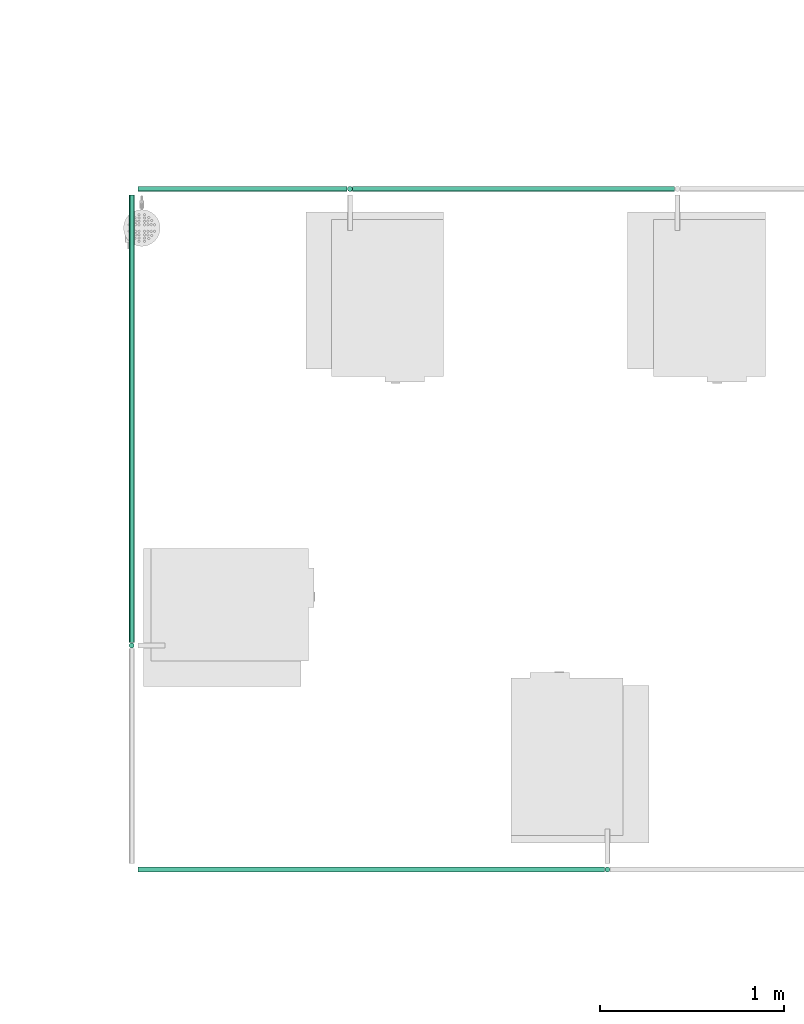
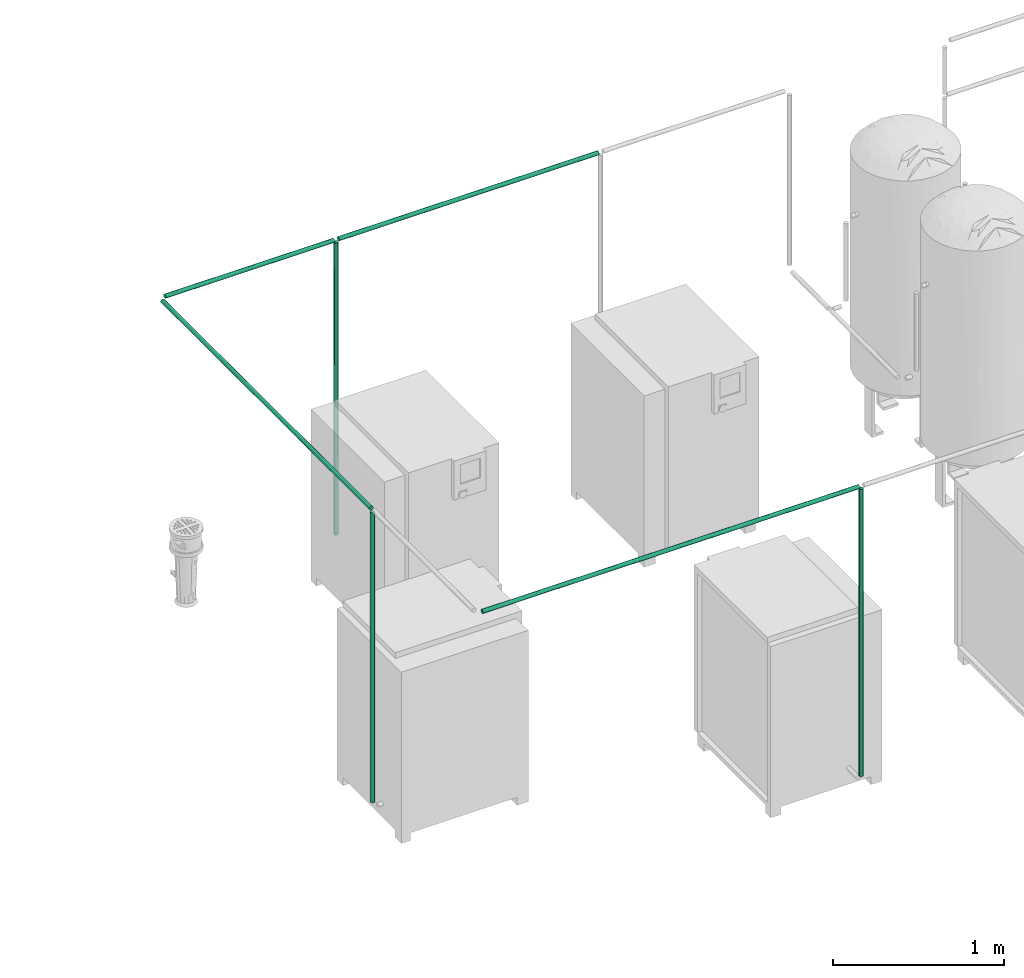
# One storey, part 38 of 331: 7 flow segments.
"""IFC2X3 building model written with IfcOpenShell, lengths in millimetres."""

from ifc_helpers import new_model, entity, si_unit, converted_unit, derived_unit, direction, frame, frame_2d, origin, origin_2d_with_axis, place, context, subcontext, project, spatial, circle, extrude, type_object, element, save


model = new_model("IFC2X3")

# Units and contexts
model_context = context("Model", 3, precision=0.01, world=origin(), true_north=direction((6.12303176911189e-17, 1.0)))
body_context = subcontext(model_context, "Body", "Model", "MODEL_VIEW")
ifc_project = project(units=[si_unit("LENGTHUNIT", "METRE", prefix="MILLI"), si_unit("AREAUNIT", "SQUARE_METRE"), si_unit("VOLUMEUNIT", "CUBIC_METRE"), converted_unit("PLANEANGLEUNIT", "DEGREE", entity("IfcRatioMeasure", 0.0174532925199433), si_unit("PLANEANGLEUNIT", "RADIAN"), dimensions=[0, 0, 0, 0, 0, 0, 0]), si_unit("MASSUNIT", "GRAM", prefix="KILO"), derived_unit("MASSDENSITYUNIT", [(si_unit("MASSUNIT", "GRAM", prefix="KILO"), 1), (si_unit("LENGTHUNIT", "METRE"), -3)]), derived_unit("MOMENTOFINERTIAUNIT", [(si_unit("LENGTHUNIT", "METRE"), 4)]), si_unit("TIMEUNIT", "SECOND"), si_unit("FREQUENCYUNIT", "HERTZ"), si_unit("THERMODYNAMICTEMPERATUREUNIT", "DEGREE_CELSIUS"), derived_unit("THERMALTRANSMITTANCEUNIT", [(si_unit("MASSUNIT", "GRAM", prefix="KILO"), 1), (si_unit("THERMODYNAMICTEMPERATUREUNIT", "KELVIN"), -1), (si_unit("TIMEUNIT", "SECOND"), -3)]), derived_unit("VOLUMETRICFLOWRATEUNIT", [(si_unit("LENGTHUNIT", "METRE"), 3), (si_unit("TIMEUNIT", "SECOND"), -1)]), derived_unit("MASSFLOWRATEUNIT", [(si_unit("MASSUNIT", "GRAM", prefix="KILO"), 1), (si_unit("TIMEUNIT", "SECOND"), -1)]), derived_unit("ROTATIONALFREQUENCYUNIT", [(si_unit("TIMEUNIT", "SECOND"), -1)]), si_unit("ELECTRICCURRENTUNIT", "AMPERE"), si_unit("ELECTRICVOLTAGEUNIT", "VOLT"), si_unit("POWERUNIT", "WATT"), si_unit("FORCEUNIT", "NEWTON", prefix="KILO"), si_unit("ILLUMINANCEUNIT", "LUX"), si_unit("LUMINOUSFLUXUNIT", "LUMEN"), si_unit("LUMINOUSINTENSITYUNIT", "CANDELA"), derived_unit("USERDEFINED", [(si_unit("MASSUNIT", "GRAM", prefix="KILO"), -1), (si_unit("LENGTHUNIT", "METRE"), -2), (si_unit("TIMEUNIT", "SECOND"), 3), (si_unit("LUMINOUSFLUXUNIT", "LUMEN"), 1)]), derived_unit("LINEARVELOCITYUNIT", [(si_unit("LENGTHUNIT", "METRE"), 1), (si_unit("TIMEUNIT", "SECOND"), -1)]), si_unit("PRESSUREUNIT", "PASCAL"), derived_unit("USERDEFINED", [(si_unit("LENGTHUNIT", "METRE"), -2), (si_unit("MASSUNIT", "GRAM", prefix="KILO"), 1), (si_unit("TIMEUNIT", "SECOND"), -2)]), derived_unit("LINEARFORCEUNIT", [(si_unit("MASSUNIT", "GRAM", prefix="KILO"), 1), (si_unit("LENGTHUNIT", "METRE"), 1), (si_unit("TIMEUNIT", "SECOND"), -2), (si_unit("LENGTHUNIT", "METRE"), -1)]), derived_unit("PLANARFORCEUNIT", [(si_unit("MASSUNIT", "GRAM", prefix="KILO"), 1), (si_unit("LENGTHUNIT", "METRE"), 1), (si_unit("TIMEUNIT", "SECOND"), -2), (si_unit("LENGTHUNIT", "METRE"), -2)])], contexts=[model_context])

# Site, building, storey
site_placement = place(None, frame((0.0, -0.00077364408347762, 0.0)))
site = spatial("IfcSite", under=ifc_project, at=site_placement, CompositionType="ELEMENT")
building_placement = place(site_placement, origin())
building = spatial("IfcBuilding", under=site, at=building_placement, CompositionType="ELEMENT")
storey_placement = place(building_placement, origin())
storey = spatial("IfcBuildingStorey", under=building, at=storey_placement, CompositionType="ELEMENT", Elevation=0.0)

# Flow segments
pipe_segment_type = type_object("IfcPipeSegmentType", PredefinedType="NOTDEFINED")
flow_segment_1_placement = place(storey_placement, frame((45767.5702717707, -670.595373934437, 1551.93082503605)))
element("IfcFlowSegment", 1, at=flow_segment_1_placement, inside=storey, type_object=pipe_segment_type, context=body_context, shape_type="SweptSolid", body=[
    extrude(circle(Radius=14.0, at=frame_2d((-6.63256116695266e-12, 0.0), x_axis=(1.0, 0.0))), frame((0.0, 15.5952722359227, 15.595272235916), z_axis=(1.0, 0.0, 0.0), x_axis=(0.0, 1.0, 0.0)), (0.0, 0.0, 1.0), 1137.72969651454),
])
flow_segment_2_placement = place(storey_placement, frame((46935.2999682852, -670.595373934439, 1551.93082503605)))
element("IfcFlowSegment", 2, at=flow_segment_2_placement, inside=storey, type_object=pipe_segment_type, context=body_context, shape_type="SweptSolid", body=[
    extrude(circle(Radius=14.0, at=frame_2d((-9.47508738136094e-13, 0.0), x_axis=(1.0, 0.0))), frame((0.0, 15.595272235917, 15.595272235916), z_axis=(1.0, 0.0, 0.0), x_axis=(0.0, 1.0, 0.0)), (0.0, 0.0, 1.0), 1750.40798741752),
])
flow_segment_3_placement = place(storey_placement, frame((46904.7046977962, -670.595373934437, -528.480570417565)))
element("IfcFlowSegment", 3, at=flow_segment_3_placement, inside=storey, type_object=pipe_segment_type, context=body_context, shape_type="SweptSolid", body=[
    extrude(circle(Radius=14.0, at=frame_2d((-1.35238486522657e-16, 0.0), x_axis=(1.0, 0.0))), frame((16.6348487488142, 15.5952722359161, 0.00699379918381151), z_axis=(-0.000499557084571514, 0.0, 0.999999875221352), x_axis=(0.999999875221352, 0.0, 0.000499557084571514)), (0.0, 0.0, 1.0), 2080.9999335547),
])
flow_segment_4_placement = place(storey_placement, frame((45717.9749995347, -3122.09979843391, 1551.93082503605)))
element("IfcFlowSegment", 4, at=flow_segment_4_placement, inside=storey, type_object=pipe_segment_type, context=body_context, shape_type="SweptSolid", body=[
    extrude(circle(Radius=14.0, at=origin_2d_with_axis()), frame((15.5952722359127, 0.0, 15.595272235916), z_axis=(0.0, 1.0, 0.0), x_axis=(-1.0, 0.0, 0.0)), (0.0, 0.0, 1.0), 2433.0996967354),
])
flow_segment_5_placement = place(storey_placement, frame((45717.9749995347, -3152.69507066983, -513.473902728047)))
element("IfcFlowSegment", 5, at=flow_segment_5_placement, inside=storey, type_object=pipe_segment_type, context=body_context, shape_type="SweptSolid", body=[
    extrude(circle(Radius=14.0, at=origin_2d_with_axis()), frame((15.5952722359127, 15.595272235916, 0.0)), (0.0, 0.0, 1.0), 2066.00000000002),
])
flow_segment_6_placement = place(storey_placement, frame((45767.5702717706, -4370.59537393444, 1551.93082503605)))
element("IfcFlowSegment", 6, at=flow_segment_6_placement, inside=storey, type_object=pipe_segment_type, context=body_context, shape_type="SweptSolid", body=[
    extrude(circle(Radius=14.0, at=origin_2d_with_axis()), frame((0.0, 15.595272235916, 15.595272235916), z_axis=(1.0, 0.0, 0.0), x_axis=(0.0, -1.0, 0.0)), (0.0, 0.0, 1.0), 2537.22029032187),
])
flow_segment_7_placement = place(storey_placement, frame((48304.1952898566, -4370.59537393443, -493.473902728048)))
element("IfcFlowSegment", 7, at=flow_segment_7_placement, inside=storey, type_object=pipe_segment_type, context=body_context, shape_type="SweptSolid", body=[
    extrude(circle(Radius=14.0, at=origin_2d_with_axis()), frame((15.5952722359127, 15.595272235916, 0.0)), (0.0, 0.0, 1.0), 2046.00000000002),
])

save(model, "model.ifc")
